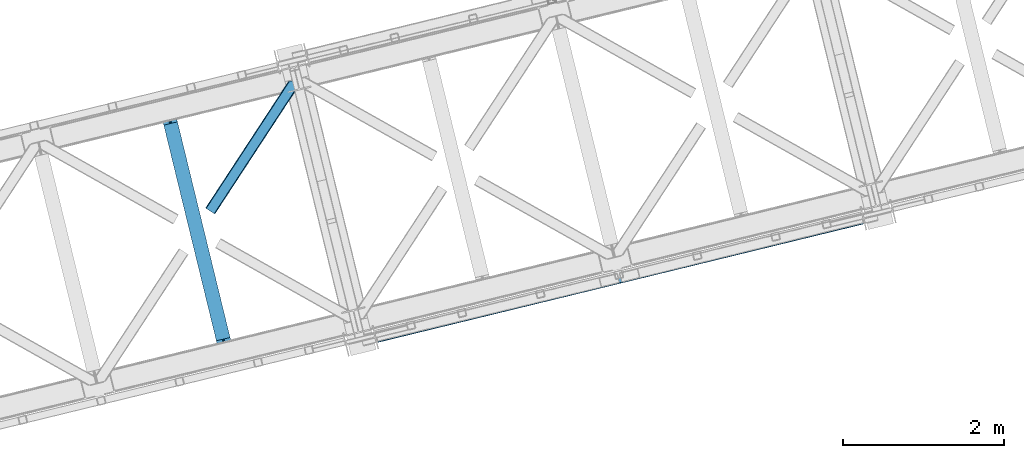
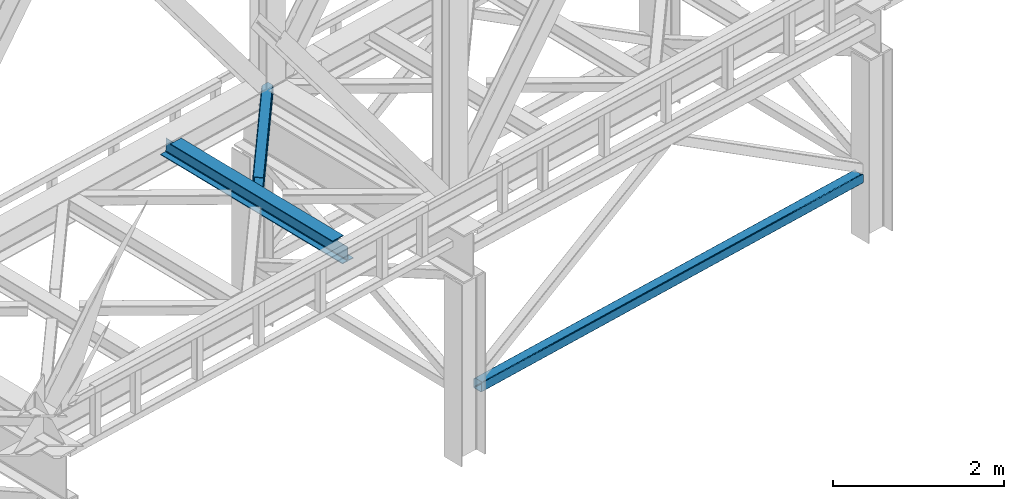
# One storey, part 44 of 92: 2 members, 1 beam.
"""IFC4 building model written with IfcOpenShell, lengths in millimetres."""

import ifcopenshell
import ifcopenshell.guid

model = None  # the IFC model being written
_history = None  # IfcOwnerHistory: only IFC2X3 demands one
_inside = {}  # id of a spatial element -> (the spatial element, [elements in it])
_under = {}  # id of a project, library or spatial element -> (it, [spatial elements below it])
_declared = {}  # id of a project -> (the project, [libraries it declares])
_typed = {}  # id of a type object -> (the type object, [elements of that type])
_made_of = {}  # id of a material, layer set ... -> (it, [elements and type objects made of it])


def new_model(schema):
    """Start an empty IFC model of exactly this schema.

    Asked for "IFC4X3", IfcOpenShell would pick the latest addendum, in which some entities
    have other attributes; the version numbers below select the first issue.
    IFC2X3 requires an IfcOwnerHistory on every rooted entity: one is made here for all.
    """
    global model, _history
    if schema == "IFC4X3":
        model = ifcopenshell.file(schema_version=(4, 3, 0, 0))
    else:
        model = ifcopenshell.file(schema=schema)
    _inside.clear()
    _under.clear()
    _declared.clear()
    _typed.clear()
    _made_of.clear()
    _history = None
    if model.schema == "IFC2X3":
        org = make("IfcOrganization", Name="unknown")
        user = make(
            "IfcPersonAndOrganization",
            ThePerson=make("IfcPerson", FamilyName="unknown"),
            TheOrganization=org,
        )
        app = make(
            "IfcApplication",
            ApplicationDeveloper=org,
            Version="unknown",
            ApplicationFullName="unknown",
            ApplicationIdentifier="unknown",
        )
        _history = make(
            "IfcOwnerHistory",
            OwningUser=user,
            OwningApplication=app,
            ChangeAction="ADDED",
            CreationDate=0,
        )
    return model


def make(cls, **values):
    """One entity of the class cls with the attributes given. An attribute that is None is left unset."""
    return model.create_entity(
        cls, **{name: value for name, value in values.items() if value is not None}
    )


def entity(cls, *values):
    """Any entity or typed value of the class cls, its attributes in the order of the schema. None: left unset."""
    e = model.create_entity(cls)
    for i, value in enumerate(values):
        if value is not None:
            e[i] = value
    return e


def rooted(cls, **values):
    """An entity with a GlobalId (a new one), such as an element, a storey or a relation."""
    return make(cls, GlobalId=ifcopenshell.guid.new(), OwnerHistory=_history, **values)


def si_unit(unit_type, name, prefix=None):
    """IfcSIUnit, for example si_unit("LENGTHUNIT", "METRE", prefix="MILLI")."""
    return make("IfcSIUnit", UnitType=unit_type, Prefix=prefix, Name=name)


def converted_unit(unit_type, name, factor, base, dimensions=None, offset=None):
    """IfcConversionBasedUnit, such as the inch: factor (a typed value) times the base unit."""
    return make(
        "IfcConversionBasedUnit"
        if offset is None
        else "IfcConversionBasedUnitWithOffset",
        ConversionOffset=offset,
        Dimensions=None
        if dimensions is None
        else entity("IfcDimensionalExponents", *dimensions),
        UnitType=unit_type,
        Name=name,
        ConversionFactor=make(
            "IfcMeasureWithUnit", ValueComponent=factor, UnitComponent=base
        ),
    )


def derived_unit(unit_type, elements):
    """IfcDerivedUnit: a product of units, each with its exponent."""
    return make(
        "IfcDerivedUnit",
        Elements=[
            make("IfcDerivedUnitElement", Unit=unit, Exponent=power)
            for unit, power in elements
        ],
        UnitType=unit_type,
    )


def assignment(units):
    """IfcUnitAssignment: the units of a project."""
    return None if units is None else make("IfcUnitAssignment", Units=units)


def point(xyz):
    """IfcCartesianPoint."""
    return None if xyz is None else make("IfcCartesianPoint", Coordinates=xyz)


def direction(xyz):
    """IfcDirection."""
    return None if xyz is None else make("IfcDirection", DirectionRatios=xyz)


def frame(location, z_axis=None, x_axis=None):
    """IfcAxis2Placement3D, a coordinate frame: its origin and axes. An axis left out is left unset."""
    return make(
        "IfcAxis2Placement3D",
        Location=point(location),
        Axis=direction(z_axis),
        RefDirection=direction(x_axis),
    )


def origin():
    """The frame at (0, 0, 0) with its axes left unset."""
    return frame((0.0, 0.0, 0.0))


def place(relative_to, where):
    """IfcLocalPlacement: puts the frame where relative to a parent placement (None: the world)."""
    return make(
        "IfcLocalPlacement", PlacementRelTo=relative_to, RelativePlacement=where
    )


def context(
    kind, dimensions, precision=None, world=None, true_north=None, identifier=None
):
    """IfcGeometricRepresentationContext, for example the 3D "Model" context."""
    return make(
        "IfcGeometricRepresentationContext",
        ContextIdentifier=identifier,
        ContextType=kind,
        CoordinateSpaceDimension=dimensions,
        Precision=precision,
        WorldCoordinateSystem=world,
        TrueNorth=true_north,
    )


def subcontext(parent, identifier, kind, view, scale=None):
    """IfcGeometricRepresentationSubContext, for example "Body" below "Model"."""
    return make(
        "IfcGeometricRepresentationSubContext",
        ContextIdentifier=identifier,
        ContextType=kind,
        ParentContext=parent,
        TargetScale=scale,
        TargetView=view,
    )


def project(units=None, contexts=None):
    """IfcProject with its units and contexts."""
    return rooted(
        "IfcProject",
        Name="project",
        RepresentationContexts=contexts,
        UnitsInContext=assignment(units),
    )


def spatial(cls, under=None, at=None, **own):
    """A site, building, storey or space (cls), placed at a placement, below another one or the project."""
    s = rooted(cls, ObjectPlacement=at, **own)
    if under is not None:
        _under.setdefault(under.id(), (under, []))[1].append(s)
    return s


def point_list(points):
    """IfcCartesianPointList2D or 3D."""
    cls = (
        "IfcCartesianPointList2D" if len(points[0]) == 2 else "IfcCartesianPointList3D"
    )
    return make(cls, CoordList=points)


def triangles(points, corners, closed=None, point_numbers=None):
    """IfcTriangulatedFaceSet: each triangle names its three corners, points numbered from 1."""
    return make(
        "IfcTriangulatedFaceSet",
        Coordinates=point_list(points),
        Closed=closed,
        CoordIndex=corners,
        PnIndex=point_numbers,
    )


def polygons(points, faces, closed=None, point_numbers=None):
    """IfcPolygonalFaceSet: a face is its outer loop, then its inner loops; points numbered from 1."""
    made = []
    for loops in faces:
        if len(loops) == 1:
            made.append(make("IfcIndexedPolygonalFace", CoordIndex=loops[0]))
        else:
            made.append(
                make(
                    "IfcIndexedPolygonalFaceWithVoids",
                    CoordIndex=loops[0],
                    InnerCoordIndices=loops[1:],
                )
            )
    return make(
        "IfcPolygonalFaceSet",
        Coordinates=point_list(points),
        Closed=closed,
        Faces=made,
        PnIndex=point_numbers,
    )


def shape(context_of_items, identifier, shape_type, items):
    """IfcShapeRepresentation: the items that make up one representation, for example the "Body"."""
    return make(
        "IfcShapeRepresentation",
        ContextOfItems=context_of_items,
        RepresentationIdentifier=identifier,
        RepresentationType=shape_type,
        Items=items,
    )


def material(Name=None, Category=None):
    """IfcMaterial."""
    return make("IfcMaterial", Name=Name, Category=Category)


def made_of(thing, what):
    """Note that an element or type object is made of a material, layer set ...; save() writes the relation."""
    if what is not None:
        _made_of.setdefault(what.id(), (what, []))[1].append(thing)
    return thing


def type_object(cls, material=None, **own):
    """A type object (cls), such as IfcWallType, which elements share."""
    return made_of(rooted(cls, **own), material)


def element(
    cls,
    number,
    at=None,
    inside=None,
    cuts=None,
    type_object=None,
    material=None,
    context=None,
    identifier="Body",
    shape_type=None,
    held_by="IfcProductDefinitionShape",
    body=None,
    shapes=None,
    **own,
):
    """One element of the class cls, such as IfcWall. Its Tag is "e" and its number.

    at: its placement. inside: the storey or other place that contains it. cuts: it is an
    opening in that element (IfcRelVoidsElement). A single representation is given by context,
    identifier, shape_type and body (its items); several are given by shapes. held_by: the class
    of the entity that holds the representations. save() writes the other relations.
    """
    e = rooted(cls, Tag="e%d" % number, ObjectPlacement=at, **own)
    if body is not None:
        shapes = [shape(context, identifier, shape_type, body)]
    if shapes is not None:
        e.Representation = make(held_by, Representations=shapes)
    if inside is not None:
        _inside.setdefault(inside.id(), (inside, []))[1].append(e)
    if cuts is not None:
        rooted(
            "IfcRelVoidsElement", RelatingBuildingElement=cuts, RelatedOpeningElement=e
        )
    if type_object is not None:
        _typed.setdefault(type_object.id(), (type_object, []))[1].append(e)
    return made_of(e, material)


def aggregate(whole, parts):
    """IfcRelAggregates: a whole, such as a stair, and the parts it consists of."""
    return rooted("IfcRelAggregates", RelatingObject=whole, RelatedObjects=parts)


def save(model, path):
    """Write the relations noted so far, then the file.

    IfcRelAggregates (storeys below a building ...), IfcRelContainedInSpatialStructure (elements
    in a storey), IfcRelDefinesByType, IfcRelAssociatesMaterial and IfcRelDeclares: one each for
    every whole, place, type object, material and project.
    """
    for whole, parts in _under.values():
        aggregate(whole, parts)
    for where, things in _inside.values():
        rooted(
            "IfcRelContainedInSpatialStructure",
            RelatedElements=things,
            RelatingStructure=where,
        )
    for kind, things in _typed.values():
        rooted("IfcRelDefinesByType", RelatedObjects=things, RelatingType=kind)
    for what, things in _made_of.values():
        rooted("IfcRelAssociatesMaterial", RelatedObjects=things, RelatingMaterial=what)
    for by, libraries in _declared.values():
        rooted("IfcRelDeclares", RelatingContext=by, RelatedDefinitions=libraries)
    model.write(path)


model = new_model("IFC4")

# Units and contexts
model_context = context("Model", 3, precision=0.01, world=origin(), true_north=direction((6.12303176911189e-17, 1.0)))
plan_context = context("Plan", 3, precision=0.01, world=origin(), true_north=direction((6.12303176911189e-17, 1.0)))
body_context = subcontext(model_context, "Body", "Model", "MODEL_VIEW")
ifc_project = project(units=[si_unit("LENGTHUNIT", "METRE", prefix="MILLI"), si_unit("AREAUNIT", "SQUARE_METRE"), si_unit("VOLUMEUNIT", "CUBIC_METRE"), converted_unit("PLANEANGLEUNIT", "DEGREE", entity("IfcRatioMeasure", 0.0174532925199433), si_unit("PLANEANGLEUNIT", "RADIAN"), dimensions=[0, 0, 0, 0, 0, 0, 0]), si_unit("MASSUNIT", "GRAM", prefix="KILO"), derived_unit("MASSDENSITYUNIT", [(si_unit("MASSUNIT", "GRAM", prefix="KILO"), 1), (si_unit("LENGTHUNIT", "METRE"), -3)]), derived_unit("MOMENTOFINERTIAUNIT", [(si_unit("LENGTHUNIT", "METRE"), 4)]), si_unit("TIMEUNIT", "SECOND"), si_unit("FREQUENCYUNIT", "HERTZ"), si_unit("THERMODYNAMICTEMPERATUREUNIT", "DEGREE_CELSIUS"), derived_unit("THERMALTRANSMITTANCEUNIT", [(si_unit("MASSUNIT", "GRAM", prefix="KILO"), 1), (si_unit("THERMODYNAMICTEMPERATUREUNIT", "KELVIN"), -1), (si_unit("TIMEUNIT", "SECOND"), -3)]), derived_unit("VOLUMETRICFLOWRATEUNIT", [(si_unit("LENGTHUNIT", "METRE"), 3), (si_unit("TIMEUNIT", "SECOND"), -1)]), derived_unit("MASSFLOWRATEUNIT", [(si_unit("MASSUNIT", "GRAM", prefix="KILO"), 1), (si_unit("TIMEUNIT", "SECOND"), -1)]), derived_unit("ROTATIONALFREQUENCYUNIT", [(si_unit("TIMEUNIT", "SECOND"), -1)]), si_unit("ELECTRICCURRENTUNIT", "AMPERE"), si_unit("ELECTRICVOLTAGEUNIT", "VOLT"), si_unit("POWERUNIT", "WATT"), si_unit("FORCEUNIT", "NEWTON", prefix="KILO"), si_unit("ILLUMINANCEUNIT", "LUX"), si_unit("LUMINOUSFLUXUNIT", "LUMEN"), si_unit("LUMINOUSINTENSITYUNIT", "CANDELA"), derived_unit("USERDEFINED", [(si_unit("MASSUNIT", "GRAM", prefix="KILO"), -1), (si_unit("LENGTHUNIT", "METRE"), -2), (si_unit("TIMEUNIT", "SECOND"), 3), (si_unit("LUMINOUSFLUXUNIT", "LUMEN"), 1)]), derived_unit("LINEARVELOCITYUNIT", [(si_unit("LENGTHUNIT", "METRE"), 1), (si_unit("TIMEUNIT", "SECOND"), -1)]), si_unit("PRESSUREUNIT", "PASCAL"), derived_unit("USERDEFINED", [(si_unit("LENGTHUNIT", "METRE"), -2), (si_unit("MASSUNIT", "GRAM", prefix="KILO"), 1), (si_unit("TIMEUNIT", "SECOND"), -2)]), derived_unit("LINEARFORCEUNIT", [(si_unit("MASSUNIT", "GRAM", prefix="KILO"), 1), (si_unit("LENGTHUNIT", "METRE"), 1), (si_unit("TIMEUNIT", "SECOND"), -2), (si_unit("LENGTHUNIT", "METRE"), -1)]), derived_unit("PLANARFORCEUNIT", [(si_unit("MASSUNIT", "GRAM", prefix="KILO"), 1), (si_unit("LENGTHUNIT", "METRE"), 1), (si_unit("TIMEUNIT", "SECOND"), -2), (si_unit("LENGTHUNIT", "METRE"), -2)])], contexts=[model_context, plan_context])

# Site, building, storey
site_placement = place(None, origin())
site = spatial("IfcSite", under=ifc_project, at=site_placement, CompositionType="ELEMENT")
building_placement = place(site_placement, origin())
building = spatial("IfcBuilding", under=site, at=building_placement, CompositionType="ELEMENT")
storey_placement = place(building_placement, frame((0.0, 0.0, 15900.0)))
storey = spatial("IfcBuildingStorey", under=building, at=storey_placement, Name="05", CompositionType="ELEMENT", Elevation=15900.0)

# Beam
ifc_material = material(Name="Metal painted (White)")
beam_type = type_object("IfcBeamType", PredefinedType="BEAM")
beam_placement = place(storey_placement, frame((-44625.41, 6908.79, 3441.0)))
element("IfcBeam", 1, at=beam_placement, inside=storey, type_object=beam_type, material=ifc_material, ObjectType="Steel Beam", PredefinedType="BEAM", context=body_context, shape_type="Tessellation", body=[
    polygons([(900.98534618944, 41.4445662733103, 11.000000000004), (900.985346189432, 41.4445662733103, 2.16573425859679e-12), (170.02161017477, 3040.13999372697, 2.16573425859679e-12), (170.02161017477, 3040.13999372697, 11.000000000004), (834.919806235823, 25.3403919499667, 11.000000000004), (103.956070221144, 3024.03581940363, 11.000000000004), (828.971056214522, 23.8903211957385, 12.2179274798217), (98.0073201998513, 3022.5857486494, 12.2179274798217), (823.927949458422, 22.6610105689205, 15.6862915010192), (92.9642134437427, 3021.35643802258, 15.6862915010192), (820.558253255246, 21.8396114687119, 20.8770650821657), (89.5945172405668, 3020.53503892237, 20.8770650821657), (819.37497330556, 21.5511744621217, 27.0000000000047), (88.4112372908809, 3020.24660191578, 27.0000000000047), (81.6103728838888, 3018.58881926485, 27.0000000000047), (81.6103728838888, 3018.58881926485, 203.000000000006), (88.4112372908723, 3020.24660191578, 203.000000000006), (8.66293703438714e-12, 2998.69542745366, 2.16573425859679e-12), (8.66293703438714e-12, 2998.69542745366, 10.9999999999997), (66.0655399536259, 3014.799601777, 11.000000000004), (72.0142899749184, 3016.24967253123, 12.2179274798217), (77.057396731027, 3017.47898315805, 15.6862915010192), (80.4270929342029, 3018.30038225826, 20.8770650821657), (819.374973305552, 21.5511744621195, 203.000000000006), (812.574108898559, 19.8933918111865, 203.000000000006), (812.574108898559, 19.8933918111886, 27.0000000000047), (811.390828948873, 19.6049548045963, 20.8770650821657), (808.021132745698, 18.7835557043887, 15.6862915010192), (802.978025989589, 17.5542450775696, 12.2179274798217), (797.029275968296, 16.1041743233436, 11.000000000004), (730.963736014671, -1.08286712929839e-12, 10.9999999999997), (730.963736014671, -1.08286712929839e-12, 2.16573425859679e-12), (779.675212882749, 184.415062601693, 203.069791966819), (128.020401343504, 2857.75452019162, 203.000000000006), (128.243282132658, 2856.84017775719, 203.617301946336), (128.256196377177, 2856.7871977843, 217.000003693143), (779.530009633824, 185.010597404073, 217.000003676718), (779.530880241722, 185.007025963194, 204.00000679514), (772.96491171832, 182.385463974442, 203.006342981529), (772.742064056782, 183.299815969775, 203.617301946336), (772.729149812263, 183.352795942668, 217.000003693143), (121.455336555608, 2855.1293963229, 217.000003676718), (121.454465947718, 2855.13296776378, 204.00000679514), (121.310166358664, 2855.72494066435, 203.076120467494), (121.21953693652, 2856.09673754069, 203.000000000006), (780.713494357868, 185.298194377514, 223.122939328039), (784.082490766547, 186.122464201394, 228.313710402595), (789.125126170554, 187.353708426698, 231.782072735464), (795.073705041266, 188.80448128138, 232.999999602236), (861.13915590679, 204.909021065316, 232.999999283132), (861.137682570352, 204.915065042188, 243.999994005812), (691.11630166644, 163.469558245298, 243.999994827032), (691.117775002877, 163.463514268425, 233.000000104353), (757.183225868401, 179.568054052359, 232.999999785253), (763.132130996739, 181.017488520583, 231.782072861012), (768.175695503862, 182.24492134372, 228.313710479427), (771.546082413611, 183.063487001149, 223.12293937232), (120.271851831572, 2854.84179934945, 223.122939328039), (116.902855422901, 2854.01752952557, 228.313710402595), (111.860220018886, 2852.78628530027, 231.782072735464), (105.911641148174, 2851.33551244559, 232.999999602236), (39.8461902826505, 2835.23097266165, 232.999999283128), (39.8476636190881, 2835.22492868478, 243.999994005812), (209.869044523001, 2876.67043548167, 243.999994827032), (209.867571186563, 2876.67647945855, 233.000000104357), (143.80212032104, 2860.57193967461, 232.999999785253), (137.853215192701, 2859.12250520638, 231.782072861012), (132.809650685579, 2857.89507238325, 228.313710479427), (129.439263775847, 2857.07650672582, 223.12293937232)], [[[1, 2, 3, 4]], [[5, 1, 4, 6]], [[7, 5, 6, 8]], [[9, 7, 8, 10]], [[11, 9, 10, 12]], [[13, 11, 12, 14]], [[15, 16, 17, 14, 12, 10, 8, 6, 4, 3, 18, 19, 20, 21, 22, 23]], [[13, 24, 25, 26, 27, 28, 29, 30, 31, 32, 2, 1, 5, 7, 9, 11]], [[2, 32, 18, 3]], [[32, 31, 19, 18]], [[31, 30, 20, 19]], [[27, 26, 15, 23]], [[28, 27, 23, 22]], [[29, 28, 22, 21]], [[30, 29, 21, 20]], [[33, 24, 13, 14, 17, 34, 35, 36, 37, 38]], [[25, 39, 40, 41, 42, 43, 44, 16, 15, 26]], [[39, 25, 24, 33]], [[45, 34, 17, 16]], [[41, 40, 38, 37, 46, 47, 48, 49, 50, 51, 52, 53, 54, 55, 56, 57]], [[42, 58, 59, 60, 61, 62, 63, 64, 65, 66, 67, 68, 69, 36, 35, 43]], [[46, 37, 36, 69]], [[47, 46, 69, 68]], [[48, 47, 68, 67]], [[49, 48, 67, 66]], [[50, 49, 66, 65]], [[51, 50, 65, 64]], [[52, 51, 64, 63]], [[53, 52, 63, 62]], [[54, 53, 62, 61]], [[55, 54, 61, 60]], [[56, 55, 60, 59]], [[57, 56, 59, 58]], [[41, 57, 58, 42]]], closed=False),
])

# Members
member_type_1 = type_object("IfcMemberType", PredefinedType="BRACE")
member_1_placement = place(storey_placement, frame((-41962.0, 7051.61, 828.01)))
element("IfcMember", 2, at=member_1_placement, inside=storey, type_object=member_type_1, ObjectType="Steel Vertical Brace", PredefinedType="BRACE", context=body_context, shape_type="Tessellation", body=[
    polygons([(31.1823923917571, 8.09507685196433, 17.8030399336136), (31.4978703677187, 6.80086440699542, 24.5000000000031), (6043.46200614716, 1472.28072783121, 24.5000000000031), (6043.1465281712, 1473.57494027617, 17.8030399336136), (30.2839871258991, 11.7806820741907, 12.1256313292342), (6042.24812290535, 1477.2605454984, 12.1256313292342), (28.9394286278191, 17.2965800886796, 8.3321081810543), (6040.90356440727, 1482.77644351289, 8.3321081810543), (27.3534137403818, 23.8030254244715, 7.00000000000274), (6039.31754951983, 1489.28288884868, 7.00000000000274), (31.4978703677187, 6.80086440699759, 115.500000000004), (1233.8906975236, 299.896837091837, 115.500000000004), (2436.28352467949, 592.992809776679, 115.500000000004), (3638.67635183539, 886.088782461522, 115.500000000004), (4841.06917899127, 1179.18475514637, 115.500000000004), (6043.46200614717, 1472.28072783121, 115.500000000004), (5.80223927826989, 112.214262715346, 7.00000000000274), (6017.76637505771, 1577.69412613956, 7.00000000000274), (33.1556530186517, 4.33146851719357e-12, 122.500000000002), (32.9849521637692, 0.70028080435977, 127.470710872505), (30.3790786276877, 11.3905800246047, 127.459370852399), (31.1823923917571, 8.09507685197083, 122.196960066387), (4.2162243908326, 118.720708051138, 8.3321081810543), (2.87166589275257, 124.236606065628, 12.1256313292385), (1.9732606268946, 127.922211287853, 17.8030399336136), (1.65778265093302, 129.216423732822, 24.5000000000031), (1.65778265093302, 129.216423732822, 115.500000000004), (1.9732606268946, 127.922211287853, 122.196960066391), (2.75016907863471, 124.735032899934, 127.339137700075), (0.16083565518386, 135.357478193014, 127.327869657831), (8.66293703438714e-12, 136.017288139813, 122.500000000002), (8.66293703438714e-12, 136.017288139814, 17.5000000000025), (0.315477975961585, 134.723075694843, 10.8030399336086), (1.21388324181955, 131.037470472619, 5.12563132923576), (2.55844173989092, 125.521572458127, 1.3321081810559), (4.14445662733688, 119.015127122336, 0.0), (29.0111963913235, 17.0021610174815, 4.33146851719357e-12), (30.5972112787521, 10.4957156816907, 1.3321081810559), (31.9417697768408, 4.97981766719959, 5.12563132923576), (32.8401750426901, 1.29421244497649, 10.8030399336086), (33.1556530186517, 6.49720277579036e-12, 17.5000000000025), (6042.34389731236, 1476.86764190793, 127.456289660221), (6044.94930417642, 1466.17925715645, 127.467627737819), (6045.1197887981, 1465.47986342422, 122.500000000002), (6045.1197887981, 1465.47986342422, 17.5000000000025), (6044.80431082214, 1466.77407586919, 10.8030399336086), (6043.90590555628, 1470.45968109141, 5.12563132923576), (6042.5613470582, 1475.9755791059, 1.3321081810559), (6040.97533217076, 1482.48202444169, 4.33146851719357e-12), (6016.10859240678, 1584.49499054655, 0.0), (6014.52257751935, 1591.00143588234, 1.3321081810559), (6013.17801902126, 1596.51733389683, 5.12563132923576), (6012.27961375541, 1600.20293911905, 10.8030399336086), (6011.96413577945, 1601.49715156402, 17.5000000000025), (6011.96413577944, 1601.49715156402, 122.500000000002), (6012.12476173557, 1600.83820188374, 127.324783556899), (6014.71363318048, 1590.21765180486, 127.336049676581), (6013.93739640643, 1593.40207471184, 122.196960066242), (6013.62191843038, 1594.69628715703, 115.500000000004), (6013.62191843038, 1594.69628715703, 24.5000000000031), (6013.93739640634, 1593.40207471206, 17.8030399336136), (6014.83580167219, 1589.71646948984, 12.1256313292385), (6016.18036017028, 1584.20057147535, 8.3321081810543), (6043.1465281712, 1473.57494027618, 122.196960066387), (4811.22909127449, 1301.60031447219, 115.500000000004), (3608.83626411861, 1008.50434178735, 115.500000000004), (2406.44343696271, 715.408369102506, 115.500000000004), (1204.05060980682, 422.312396417664, 115.500000000004), (3636.11791009549, 896.584498143207, 131.667891818951), (3634.53189520805, 903.090943478997, 133.000000000002), (4836.92472236395, 1196.18691616384, 133.000000000002), (4838.51073725137, 1189.68047082805, 131.667891818951), (2433.7250829396, 603.488525458366, 131.667891818951), (2432.13906805216, 609.994970794154, 133.000000000002), (1231.33225578371, 310.39255277352, 131.667891818951), (1229.74624089627, 316.898998109313, 133.000000000002), (3637.46246859358, 891.068600128714, 127.874368670766), (4839.85529574946, 1184.16457281356, 127.874368670769), (2435.06964143769, 597.972627443875, 127.874368670766), (1232.67681428179, 304.876654759037, 127.874368670764), (3638.36087385943, 887.38299490649, 122.196960066391), (4840.75370101532, 1180.47896759133, 122.196960066391), (2435.96804670354, 594.287022221649, 122.196960066391), (1233.57521954764, 301.1910495368, 122.196960066398), (31.5502884877899, 12.1280669225079, 127.832051495924), (6022.29628381583, 1481.61972718141, 132.663742407058), (6026.48870551306, 1479.26266915122, 131.667891818946), (6032.74268487119, 1477.67303378224, 130.050718215297), (6040.81788497076, 1476.91190987021, 127.874368670771), (6020.32653219421, 1484.65362745456, 133.000000000002), (45.9812256023699, 24.8297035737187, 132.663742407058), (46.3338903742774, 28.4297174134712, 133.000000000002), (43.3437470141199, 20.8077850900284, 131.667891818946), (38.5228114325978, 16.5185220342153, 130.050718215297), (4811.54456925045, 1300.30610202723, 122.196960066398), (3609.15174209456, 1007.21012934238, 122.196960066391), (2406.75891493868, 714.114156657538, 122.196960066391), (1204.36608778278, 421.018183972693, 122.196960066391), (3610.05014736042, 1003.52452412015, 127.874368670766), (4812.44297451631, 1296.62049680499, 127.874368670764), (2407.65732020453, 710.428551435313, 127.874368670766), (1205.26449304863, 417.332578750467, 127.874368670769), (3611.3947058585, 998.008626105663, 131.667891818951), (4813.78753301439, 1291.10459879051, 131.667891818951), (2409.00187870262, 704.912653420823, 131.667891818951), (1206.60905154672, 411.816680735979, 131.667891818951), (3612.98072074593, 991.502180769872, 133.000000000002), (4815.37354790183, 1284.59815345471, 133.000000000002), (2410.58789359004, 698.406208085028, 133.000000000002), (1208.19506643415, 405.310235400188, 133.000000000002), (23.1575293538741, 119.958846357108, 132.663742407058), (18.9882333015665, 122.321541507905, 131.667891818946), (12.7555666598902, 123.916372077005, 130.050718215297), (4.69904731255704, 124.682049620023, 127.874368670766), (6013.19574048155, 1589.26651108978, 127.819900969506), (5998.78345494397, 1576.58088659697, 132.663742407058), (5998.45484003982, 1572.98673516693, 133.000000000002), (6001.39780788741, 1580.59716796007, 131.667891818951), (6006.19743075267, 1584.88123581581, 130.050718215297), (25.1032311076897, 116.919083674242, 133.000000000002), (47.3930810011482, 129.557436874889, 140.000000000007), (45.4473792473327, 132.597199557755, 139.663742407063), (41.278083195025, 134.959894708553, 138.667891818953), (35.0454165533487, 136.554725277652, 137.050718215302), (26.9888972060156, 137.320402820668, 134.874368670771), (17.4181326733936, 137.227502779025, 132.222479077847), (6.70092206914705, 136.279595249225, 129.196960066394), (38.4509956920848, 2.83027378408815, 129.123005654579), (48.7045272230404, 6.82584207131562, 132.222479077849), (57.2597898737891, 11.1513529252108, 134.874368670767), (64.0789165978297, 15.5431265793589, 137.0507182153), (68.8998521793605, 19.832389635172, 138.667891818951), (71.5373307676018, 23.8543081188612, 139.663742407063), (71.8899955395179, 27.4543219586159, 140.000000000005), (6006.19810950404, 1598.53794428522, 129.117414315577), (5995.93239309075, 1594.55360519101, 132.222479077843), (5987.39246133695, 1590.23183140545, 134.874368670761), (5980.59201536491, 1585.84461138224, 137.050718215296), (5975.79239249968, 1581.5605435265, 138.667891818947), (5973.17803955624, 1577.5442621634, 139.663742407056), (5972.8494246521, 1573.95011073336, 140.000000000001), (5998.08599252255, 1472.02729414216, 140.000000000001), (6000.05574414416, 1468.99339386901, 139.663742407058), (6004.24816584138, 1466.63633583883, 138.667891818949), (6010.50214519951, 1465.04670046984, 137.050718215298), (6018.57734529909, 1464.28557655783, 134.874368670763), (6028.16344072891, 1464.38221366786, 132.222479077841), (6038.89204321754, 1465.33289809, 129.19696006639), (4813.71576525089, 1291.3990178617, 140.000000000003), (3611.322938095, 998.303045176863, 140.000000000003), (2408.93011093911, 705.207072492022, 140.000000000003), (1206.53728378322, 412.111099807177, 140.000000000003), (1231.40402354721, 310.098133702322, 140.000000000003), (2433.79685070309, 603.194106387163, 140.000000000003), (3636.18967785899, 896.290079072006, 140.000000000003), (4838.58250501488, 1189.38605175685, 140.000000000003), (3640.01865651036, 880.5821304995, 129.196960066392), (3640.33413448632, 879.287918054531, 122.500000000002), (4842.72696164221, 1172.38389073937, 122.500000000002), (4842.41148366625, 1173.67810318434, 129.19696006639), (2437.62582935447, 587.486157814659, 129.196960066392), (2437.94130733042, 586.191945369687, 122.500000000002), (1235.23300219857, 294.390185129813, 129.196960066386), (1235.54848017454, 293.095972684847, 122.500000000002), (3639.12025124451, 884.267735721724, 134.874368670767), (4841.51307840039, 1177.36370840657, 134.874368670767), (2436.72742408863, 591.171763036885, 134.874368670767), (1234.33459693272, 298.075790352039, 134.874368670767), (3637.77569274642, 889.783633736217, 138.667891818951), (4840.16851990231, 1182.87960642106, 138.667891818951), (2435.38286559054, 596.687661051376, 138.667891818951), (1232.99003843464, 303.591688366532, 138.667891818951), (3609.73692320756, 1004.80949051265, 138.667891818951), (4812.12975036345, 1297.90546319749, 138.667891818951), (2407.34409605168, 711.713517827812, 138.667891818951), (1204.95126889577, 418.617545142969, 138.667891818951), (3608.39236470948, 1010.32538852714, 134.874368670767), (4810.78519186538, 1303.42136121199, 134.874368670767), (2405.9995375536, 717.229415842302, 134.874368670767), (1203.60671039769, 424.133443157459, 134.874368670767), (3607.49395944363, 1014.01099374937, 129.196960066392), (4809.88678659952, 1307.10696643421, 129.196960066386), (2405.10113228775, 720.915021064528, 129.196960066392), (1202.70830513185, 427.819048379684, 129.19696006639), (3607.17848146767, 1015.30520619434, 122.500000000002), (4809.57130862356, 1308.40117887918, 122.500000000002), (2404.78565431178, 722.209233509496, 122.500000000002), (1202.39282715589, 429.113260824654, 122.500000000002)], [[[1, 2, 3, 4]], [[5, 1, 4, 6]], [[7, 5, 6, 8]], [[9, 7, 8, 10]], [[2, 11, 12, 13, 14, 15, 16, 3]], [[17, 9, 10, 18]], [[19, 20, 21, 22, 11, 2, 1, 5, 7, 9, 17, 23, 24, 25, 26, 27, 28, 29, 30, 31, 32, 33, 34, 35, 36, 37, 38, 39, 40, 41]], [[42, 43, 44, 45, 46, 47, 48, 49, 50, 51, 52, 53, 54, 55, 56, 57, 58, 59, 60, 61, 62, 63, 18, 10, 8, 6, 4, 3, 16, 64]], [[23, 17, 18, 63]], [[24, 23, 63, 62]], [[25, 24, 62, 61]], [[26, 25, 61, 60]], [[27, 26, 60, 59, 65, 66, 67, 68]], [[69, 70, 71, 72]], [[73, 74, 70, 69]], [[75, 76, 74, 73]], [[77, 69, 72, 78]], [[79, 73, 69, 77]], [[80, 75, 73, 79]], [[81, 77, 78, 82]], [[83, 79, 77, 81]], [[84, 80, 79, 83]], [[15, 82, 64, 16]], [[14, 81, 82, 15]], [[13, 83, 81, 14]], [[12, 84, 83, 13]], [[11, 22, 84, 12]], [[84, 85, 80]], [[72, 86, 87]], [[78, 88, 89]], [[64, 89, 42]], [[89, 64, 82, 78]], [[78, 87, 88]], [[87, 78, 72]], [[72, 90, 86]], [[90, 72, 71]], [[76, 91, 92]], [[75, 91, 76]], [[91, 75, 93]], [[75, 94, 93]], [[80, 94, 75]], [[94, 80, 85]], [[85, 22, 21]], [[85, 84, 22]], [[95, 65, 59, 58]], [[96, 66, 65, 95]], [[97, 67, 66, 96]], [[98, 68, 67, 97]], [[28, 27, 68, 98]], [[99, 96, 95, 100]], [[101, 97, 96, 99]], [[102, 98, 97, 101]], [[103, 99, 100, 104]], [[105, 101, 99, 103]], [[106, 102, 101, 105]], [[107, 103, 104, 108]], [[109, 105, 103, 107]], [[110, 106, 105, 109]], [[106, 111, 112]], [[102, 113, 114]], [[28, 114, 29]], [[95, 115, 100]], [[108, 116, 117]], [[104, 116, 108]], [[116, 104, 118]], [[104, 119, 118]], [[100, 119, 104]], [[119, 100, 115]], [[115, 58, 57]], [[115, 95, 58]], [[114, 28, 98, 102]], [[102, 112, 113]], [[112, 102, 106]], [[106, 120, 111]], [[120, 106, 110]], [[92, 120, 110, 109, 107, 108, 117, 90, 71, 70, 74, 76]], [[121, 122, 123, 124, 125, 126, 127, 30, 29, 114, 113, 112, 111, 120, 92, 91, 93, 94, 85, 21, 20, 128, 129, 130, 131, 132, 133, 134]], [[135, 136, 137, 138, 139, 140, 141, 142, 143, 144, 145, 146, 147, 148, 43, 42, 89, 88, 87, 86, 90, 117, 116, 118, 119, 115, 57, 56]], [[141, 149, 150, 151, 152, 121, 134, 153, 154, 155, 156, 142]], [[157, 158, 159, 160]], [[161, 162, 158, 157]], [[163, 164, 162, 161]], [[165, 157, 160, 166]], [[167, 161, 157, 165]], [[168, 163, 161, 167]], [[169, 165, 166, 170]], [[171, 167, 165, 169]], [[172, 168, 167, 171]], [[155, 169, 170, 156]], [[154, 171, 169, 155]], [[153, 172, 171, 154]], [[172, 133, 132]], [[168, 131, 130]], [[163, 129, 128]], [[19, 128, 20]], [[44, 148, 160, 159]], [[156, 143, 142]], [[170, 143, 156]], [[143, 170, 144]], [[170, 145, 144]], [[166, 145, 170]], [[145, 166, 146]], [[166, 147, 146]], [[160, 147, 166]], [[147, 160, 148]], [[148, 44, 43]], [[164, 128, 19]], [[128, 164, 163]], [[163, 130, 129]], [[130, 163, 168]], [[168, 132, 131]], [[132, 168, 172]], [[172, 134, 133]], [[134, 172, 153]], [[173, 150, 149, 174]], [[175, 151, 150, 173]], [[176, 152, 151, 175]], [[177, 173, 174, 178]], [[179, 175, 173, 177]], [[180, 176, 175, 179]], [[181, 177, 178, 182]], [[183, 179, 177, 181]], [[184, 180, 179, 183]], [[185, 181, 182, 186]], [[187, 183, 181, 185]], [[188, 184, 183, 187]], [[31, 127, 184, 188]], [[174, 140, 139]], [[178, 138, 137]], [[182, 136, 135]], [[55, 135, 56]], [[186, 135, 55]], [[135, 186, 182]], [[182, 137, 136]], [[137, 182, 178]], [[178, 139, 138]], [[139, 178, 174]], [[174, 141, 140]], [[141, 174, 149]], [[152, 122, 121]], [[176, 122, 152]], [[122, 176, 123]], [[176, 124, 123]], [[180, 124, 176]], [[124, 180, 125]], [[180, 126, 125]], [[184, 126, 180]], [[126, 184, 127]], [[127, 31, 30]], [[19, 41, 45, 44, 159, 158, 162, 164]], [[38, 37, 49, 48]], [[39, 38, 48, 47]], [[40, 39, 47, 46]], [[41, 40, 46, 45]], [[32, 31, 188, 187, 185, 186, 55, 54]], [[33, 32, 54, 53]], [[34, 33, 53, 52]], [[35, 34, 52, 51]], [[36, 35, 51, 50]], [[37, 36, 50, 49]]], closed=True),
])
member_type_2 = type_object("IfcMemberType", PredefinedType="BRACE")
member_2_placement = place(storey_placement, frame((-44069.14, 8641.5, 3511.0)))
element("IfcMember", 3, at=member_2_placement, inside=storey, type_object=member_type_2, ObjectType="Steel Horizontal Brace", PredefinedType="BRACE", context=body_context, shape_type="Tessellation", body=[
    triangles([(994.771838378911, 1564.02662658691, 0.0), (1028.82092285156, 1424.34794311523, 0.0), (14.6409667968765, 67.1040435791019, 0.0), (102.486767578128, 9.58604278564417, 0.0), (1.1162109375, 75.9604797363281, 10.8028289794929), (0.0, 76.6900863647461, 17.5000946044929), (1025.02580566407, 1642.17883300781, 17.5000946044929), (4.28811035156832, 73.8821182250977, 5.12526855468968), (990.474426269531, 1585.8776184082, 9.50058288574292), (990.041894531256, 1584.44747314453, 8.74132690429906), (989.90701904297, 1583.99168701172, 8.50064392089917), (990.758129882815, 1580.48841247559, 5.12526855468968), (1027.30938720703, 1642.73461303711, 10.8702667236357), (1027.77912597657, 1642.84972229004, 9.50058288574292), (992.599877929693, 1572.93538513184, 1.33247680664135), (9.03665771484521, 70.7724243164066, 1.33247680664135), (1025.02580566407, 1642.17883300781, 122.500662231447), (0.0, 76.6900863647461, 122.500662231447), (1026.92336425782, 1642.64043273926, 129.197927856447), (1.1162109375, 75.9604797363281, 129.197927856447), (1032.31838378907, 1643.95546875, 134.874325561526), (4.28811035156832, 73.8821182250977, 134.874325561526), (1040.39230957031, 1645.92395324707, 138.667117309571), (9.03665771484521, 70.7724243164066, 138.667117309571), (1049.91730957032, 1648.24590454102, 139.999594116212), (14.6409667968765, 67.1040435791019, 139.999594116212), (994.869506835938, 1567.85081176758, 9.50058288574292), (994.75788574219, 1567.00667724609, 9.29478149414354), (994.650915527345, 1566.15091552734, 9.08781738281323), (994.539294433598, 1565.30561828613, 8.8831787109375), (994.74393310547, 1564.14522399902, 8.50064392089917), (1047.05236816406, 1647.54827270508, 9.50058288574292), (14.8921142578183, 66.9377746582031, 8.3320495605476), (20.4964233398496, 63.2693939208984, 6.99957275390625), (997.041467285162, 1554.71440429688, 6.99957275390625), (10.1435668945342, 70.0480499267578, 12.1260040283232), (1042.27126464844, 1646.38322753906, 12.1260040283232), (1036.87624511719, 1645.06702880859, 17.8035644531265), (1034.98333740234, 1644.60542907715, 24.4996673583992), (6.97166748047312, 72.1258300781246, 17.8035644531265), (5.85545654297312, 72.8554367065426, 24.4996673583992), (1026.55129394532, 1433.65900268555, 6.99957275390625), (96.6266601562529, 13.4206924438477, 6.99957275390625), (1028.71860351563, 1424.77698669434, 8.41343994140698), (1032.83463134766, 1407.88615722656, 5.12526855468968), (1033.6857421875, 1404.3817199707, 8.50064392089917), (1030.99288330079, 1415.43918457031, 1.33247680664135), (1034.98333740234, 1644.60542907715, 115.501089477541), (5.85545654297312, 72.8554367065426, 115.501089477541), (1050.3498413086, 1648.35171203613, 131.667544555665), (1059.8748413086, 1650.67250061035, 133.000021362306), (20.4964233398496, 63.2693939208984, 133.000021362306), (14.8921142578183, 66.9377746582031, 131.667544555665), (1042.27126464844, 1646.38322753906, 127.87475280762), (10.1435668945342, 70.0480499267578, 127.87475280762), (1036.87624511719, 1645.06702880859, 122.196029663086), (6.97166748047312, 72.1258300781246, 122.196029663086), (1128.10788574219, 1667.30520629883, 139.999594116212), (1128.10788574219, 1667.30520629883, 133.000021362306), (1144.33015136719, 1600.75810546875, 139.999594116212), (102.486767578128, 9.58604278564417, 139.999594116212), (1142.06052246094, 1610.07032775879, 133.000021362306), (96.6266601562529, 13.4206924438477, 133.000021362306), (1146.50211181641, 1591.84934692383, 138.667117309571), (108.08642578125, 5.91766204833948, 138.667117309571), (1148.33920898438, 1584.29631958008, 134.874325561526), (112.834973144534, 2.80738677978479, 134.874325561526), (1149.57169189453, 1579.2501159668, 129.197927856447), (116.011523437504, 0.729606628417969, 129.197927856447), (1150.00422363282, 1577.47813110351, 122.500662231447), (117.127734375004, 0.0, 122.500662231447), (1150.00422363282, 1577.47813110351, 17.5000946044929), (117.127734375004, 0.0, 17.5000946044929), (106.979516601568, 6.64203643798828, 127.87475280762), (110.156066894531, 4.56425628662146, 122.196029663086), (111.267626953129, 3.83406829833984, 115.501089477541), (102.230969238284, 9.75231170654297, 131.667544555665), (116.011523437504, 0.729606628417969, 10.8028289794929), (106.979516601568, 6.64203643798828, 12.1260040283232), (112.834973144534, 2.80738677978479, 5.12526855468968), (111.267626953129, 3.83406829833984, 24.4996673583992), (110.156066894531, 4.56425628662146, 17.8035644531265), (108.08642578125, 5.91766204833948, 1.33247680664135), (102.230969238284, 9.75231170654297, 8.3320495605476), (1147.30206298828, 1588.56233825684, 122.196029663086), (1147.73459472656, 1586.79035339356, 115.501089477541), (1146.06958007813, 1593.60854187012, 127.87475280762), (1144.23248291016, 1601.16040649414, 131.667544555665), (1147.73459472656, 1586.79035339356, 24.4996673583992), (1147.21369628907, 1588.9239440918, 17.869839477542), (1149.994921875, 1577.51650085449, 16.5001556396492), (1147.10672607422, 1589.36461486816, 16.5001556396492), (1145.27427978516, 1573.10863037109, 10.8714294433594), (1034.62056884766, 1404.788671875, 9.50058288574292), (1144.12551269532, 1572.03427734375, 9.50058288574292), (1142.79071044922, 1588.59721984863, 12.1260040283232), (1030.22548828126, 1422.8143157959, 9.50058288574292), (1029.19764404297, 1423.6724029541, 8.80643920898729), (1139.73043212891, 1590.05992126465, 9.50058288574292)], [[1, 2, 3], [4, 3, 2], [5, 6, 7], [8, 9, 10], [11, 12, 8], [5, 13, 9], [9, 8, 5], [13, 14, 9], [15, 1, 16], [3, 16, 1], [12, 15, 8], [16, 8, 15], [7, 13, 5], [17, 7, 6], [6, 18, 17], [19, 17, 20], [18, 20, 17], [21, 19, 22], [20, 22, 19], [23, 21, 24], [22, 24, 21], [25, 23, 26], [24, 26, 23], [27, 28, 9], [28, 29, 10], [29, 30, 10], [30, 31, 11], [14, 32, 27], [27, 9, 14], [33, 34, 35], [36, 33, 31], [31, 30, 36], [28, 36, 29], [28, 27, 36], [36, 30, 29], [32, 37, 27], [36, 27, 37], [35, 31, 33], [38, 39, 40], [41, 40, 39], [37, 38, 36], [40, 36, 38], [42, 35, 34], [34, 43, 42], [1, 35, 42], [31, 12, 11], [1, 31, 35], [31, 15, 12], [31, 1, 15], [2, 1, 42], [44, 2, 42], [45, 44, 46], [44, 47, 2], [44, 45, 47], [39, 48, 41], [49, 41, 48], [50, 51, 52], [52, 53, 50], [54, 50, 53], [53, 55, 54], [56, 54, 55], [55, 57, 56], [48, 56, 57], [57, 49, 48], [56, 17, 19], [50, 23, 25], [58, 51, 25], [51, 58, 59], [51, 50, 25], [54, 23, 50], [54, 56, 21], [21, 23, 54], [19, 21, 56], [39, 7, 17], [37, 14, 38], [56, 48, 17], [37, 32, 14], [39, 38, 7], [48, 39, 17], [13, 7, 38], [38, 14, 13], [60, 25, 61], [25, 60, 58], [26, 61, 25], [51, 62, 63], [51, 59, 62], [63, 52, 51], [64, 60, 61], [61, 65, 64], [66, 64, 65], [65, 67, 66], [68, 66, 67], [67, 69, 68], [70, 68, 69], [69, 71, 70], [72, 70, 71], [71, 73, 72], [69, 74, 75], [76, 73, 71], [69, 75, 71], [69, 67, 74], [75, 76, 71], [74, 67, 65], [63, 61, 26], [61, 77, 65], [77, 61, 63], [77, 74, 65], [78, 79, 80], [81, 73, 76], [73, 82, 78], [82, 73, 81], [78, 82, 79], [4, 43, 3], [83, 80, 79], [79, 84, 83], [84, 43, 4], [4, 83, 84], [55, 24, 22], [26, 52, 63], [26, 53, 52], [53, 26, 24], [55, 53, 24], [49, 18, 6], [20, 57, 55], [22, 20, 55], [57, 20, 18], [49, 57, 18], [16, 36, 8], [3, 43, 34], [34, 33, 3], [33, 36, 16], [16, 3, 33], [5, 8, 36], [6, 41, 49], [40, 6, 5], [6, 40, 41], [40, 5, 36], [85, 86, 75], [76, 75, 86], [87, 85, 74], [75, 74, 85], [88, 87, 77], [74, 77, 87], [62, 88, 63], [77, 63, 88], [86, 89, 81], [81, 76, 86], [90, 91, 92], [70, 72, 89], [72, 90, 89], [89, 86, 70], [72, 91, 90], [85, 70, 86], [68, 70, 85], [66, 85, 87], [85, 66, 68], [87, 64, 66], [88, 64, 87], [88, 62, 60], [88, 60, 64], [62, 58, 60], [62, 59, 58], [73, 78, 93], [93, 72, 73], [94, 93, 78], [94, 95, 93], [80, 45, 46], [46, 78, 80], [46, 94, 78], [47, 45, 83], [80, 83, 45], [2, 47, 4], [83, 4, 47], [93, 91, 72], [82, 81, 89], [82, 92, 96], [82, 90, 92], [84, 97, 98], [79, 96, 97], [97, 84, 79], [96, 99, 97], [43, 84, 44], [44, 42, 43], [96, 79, 82], [89, 90, 82], [96, 91, 93], [96, 92, 91], [96, 95, 99], [93, 95, 96], [99, 95, 97], [94, 97, 95]]),
])

save(model, "model.ifc")
